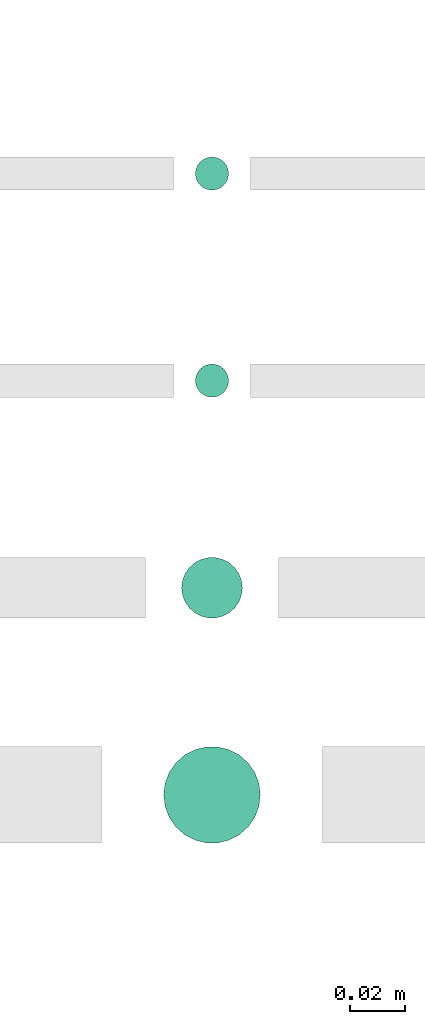
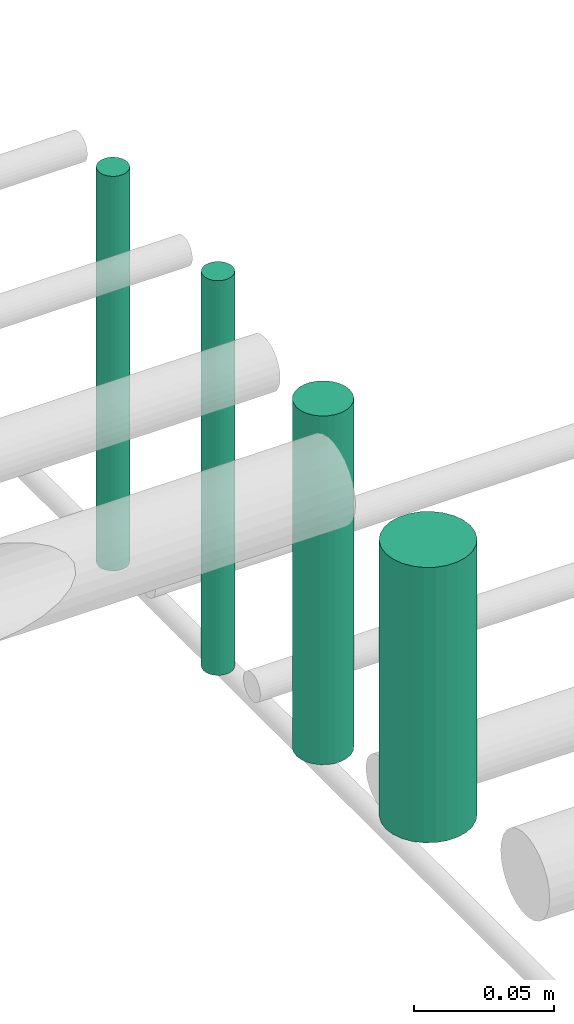
# One storey, part 181 of 331: 4 flow segments.
"""IFC2X3 building model written with IfcOpenShell, lengths in millimetres."""

from ifc_helpers import new_model, entity, si_unit, converted_unit, derived_unit, direction, frame, frame_2d, origin, origin_2d_with_axis, place, context, subcontext, project, spatial, circle, extrude, type_object, element, save


model = new_model("IFC2X3")

# Units and contexts
model_context = context("Model", 3, precision=0.01, world=origin(), true_north=direction((6.12303176911189e-17, 1.0)))
body_context = subcontext(model_context, "Body", "Model", "MODEL_VIEW")
ifc_project = project(units=[si_unit("LENGTHUNIT", "METRE", prefix="MILLI"), si_unit("AREAUNIT", "SQUARE_METRE"), si_unit("VOLUMEUNIT", "CUBIC_METRE"), converted_unit("PLANEANGLEUNIT", "DEGREE", entity("IfcRatioMeasure", 0.0174532925199433), si_unit("PLANEANGLEUNIT", "RADIAN"), dimensions=[0, 0, 0, 0, 0, 0, 0]), si_unit("MASSUNIT", "GRAM", prefix="KILO"), derived_unit("MASSDENSITYUNIT", [(si_unit("MASSUNIT", "GRAM", prefix="KILO"), 1), (si_unit("LENGTHUNIT", "METRE"), -3)]), derived_unit("MOMENTOFINERTIAUNIT", [(si_unit("LENGTHUNIT", "METRE"), 4)]), si_unit("TIMEUNIT", "SECOND"), si_unit("FREQUENCYUNIT", "HERTZ"), si_unit("THERMODYNAMICTEMPERATUREUNIT", "DEGREE_CELSIUS"), derived_unit("THERMALTRANSMITTANCEUNIT", [(si_unit("MASSUNIT", "GRAM", prefix="KILO"), 1), (si_unit("THERMODYNAMICTEMPERATUREUNIT", "KELVIN"), -1), (si_unit("TIMEUNIT", "SECOND"), -3)]), derived_unit("VOLUMETRICFLOWRATEUNIT", [(si_unit("LENGTHUNIT", "METRE"), 3), (si_unit("TIMEUNIT", "SECOND"), -1)]), derived_unit("MASSFLOWRATEUNIT", [(si_unit("MASSUNIT", "GRAM", prefix="KILO"), 1), (si_unit("TIMEUNIT", "SECOND"), -1)]), derived_unit("ROTATIONALFREQUENCYUNIT", [(si_unit("TIMEUNIT", "SECOND"), -1)]), si_unit("ELECTRICCURRENTUNIT", "AMPERE"), si_unit("ELECTRICVOLTAGEUNIT", "VOLT"), si_unit("POWERUNIT", "WATT"), si_unit("FORCEUNIT", "NEWTON", prefix="KILO"), si_unit("ILLUMINANCEUNIT", "LUX"), si_unit("LUMINOUSFLUXUNIT", "LUMEN"), si_unit("LUMINOUSINTENSITYUNIT", "CANDELA"), derived_unit("USERDEFINED", [(si_unit("MASSUNIT", "GRAM", prefix="KILO"), -1), (si_unit("LENGTHUNIT", "METRE"), -2), (si_unit("TIMEUNIT", "SECOND"), 3), (si_unit("LUMINOUSFLUXUNIT", "LUMEN"), 1)]), derived_unit("LINEARVELOCITYUNIT", [(si_unit("LENGTHUNIT", "METRE"), 1), (si_unit("TIMEUNIT", "SECOND"), -1)]), si_unit("PRESSUREUNIT", "PASCAL"), derived_unit("USERDEFINED", [(si_unit("LENGTHUNIT", "METRE"), -2), (si_unit("MASSUNIT", "GRAM", prefix="KILO"), 1), (si_unit("TIMEUNIT", "SECOND"), -2)]), derived_unit("LINEARFORCEUNIT", [(si_unit("MASSUNIT", "GRAM", prefix="KILO"), 1), (si_unit("LENGTHUNIT", "METRE"), 1), (si_unit("TIMEUNIT", "SECOND"), -2), (si_unit("LENGTHUNIT", "METRE"), -1)]), derived_unit("PLANARFORCEUNIT", [(si_unit("MASSUNIT", "GRAM", prefix="KILO"), 1), (si_unit("LENGTHUNIT", "METRE"), 1), (si_unit("TIMEUNIT", "SECOND"), -2), (si_unit("LENGTHUNIT", "METRE"), -2)])], contexts=[model_context])

# Site, building, storey
site_placement = place(None, frame((0.0, -0.00077364408347762, 0.0)))
site = spatial("IfcSite", under=ifc_project, at=site_placement, CompositionType="ELEMENT")
building_placement = place(site_placement, origin())
building = spatial("IfcBuilding", under=site, at=building_placement, CompositionType="ELEMENT")
storey_placement = place(building_placement, origin())
storey = spatial("IfcBuildingStorey", under=building, at=storey_placement, CompositionType="ELEMENT", Elevation=0.0)

# Flow segments
pipe_segment_type = type_object("IfcPipeSegmentType", PredefinedType="NOTDEFINED")
flow_segment_1_placement = place(storey_placement, frame((41813.5853316717, 8668.02529159145, 14564.0)))
element("IfcFlowSegment", 1, at=flow_segment_1_placement, inside=storey, type_object=pipe_segment_type, context=body_context, shape_type="SweptSolid", body=[
    extrude(circle(Radius=6.0, at=origin_2d_with_axis()), frame((7.59527223591454, 7.59527223591562, 0.0)), (0.0, 0.0, 1.0), 172.000000000026),
])
flow_segment_2_placement = place(storey_placement, frame((41813.5853316717, 8593.02529159145, 14564.0)))
element("IfcFlowSegment", 2, at=flow_segment_2_placement, inside=storey, type_object=pipe_segment_type, context=body_context, shape_type="SweptSolid", body=[
    extrude(circle(Radius=6.0, at=frame_2d((0.0, 1.08286712929839e-12), x_axis=(1.0, 0.0))), frame((7.59527223591454, 7.5952722359167, 0.0), z_axis=(0.0, 0.0, 1.0), x_axis=(-1.0, 0.0, 0.0)), (0.0, 0.0, 1.0), 172.000000000013),
])
flow_segment_3_placement = place(storey_placement, frame((41808.5853316717, 8513.02529159144, 14574.0)))
element("IfcFlowSegment", 3, at=flow_segment_3_placement, inside=storey, type_object=pipe_segment_type, context=body_context, shape_type="SweptSolid", body=[
    extrude(circle(Radius=11.0, at=origin_2d_with_axis()), frame((12.5952722359134, 12.5952722359156, 0.0)), (0.0, 0.0, 1.0), 152.000000000017),
])
flow_segment_4_placement = place(storey_placement, frame((41802.0853316717, 8431.52529159142, 14590.0)))
element("IfcFlowSegment", 4, at=flow_segment_4_placement, inside=storey, type_object=pipe_segment_type, context=body_context, shape_type="SweptSolid", body=[
    extrude(circle(Radius=17.5, at=origin_2d_with_axis()), frame((19.0952722359119, 19.0952722359163, 0.0), z_axis=(0.0, 0.0, 1.0), x_axis=(-1.0, 0.0, 0.0)), (0.0, 0.0, 1.0), 120.000000000062),
])

save(model, "model.ifc")
